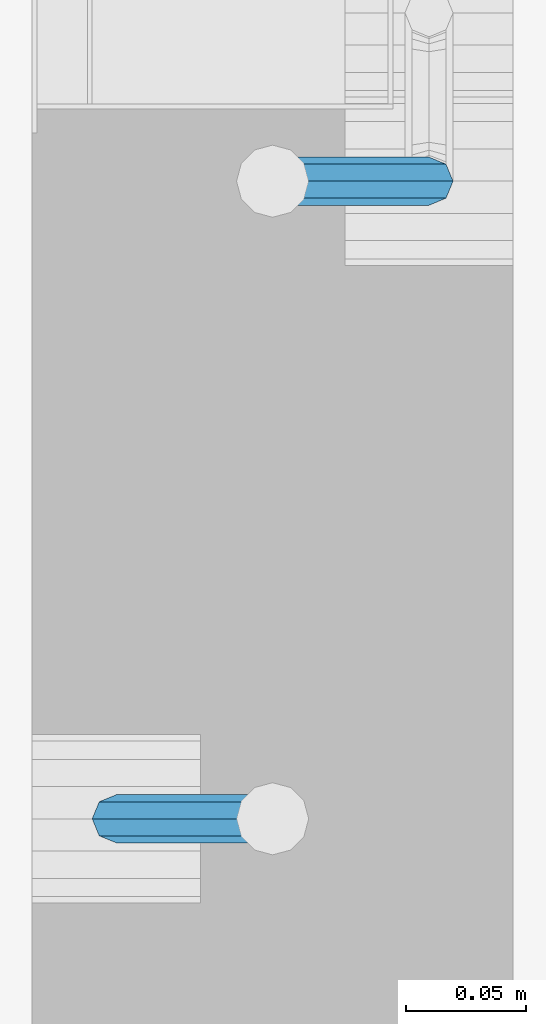
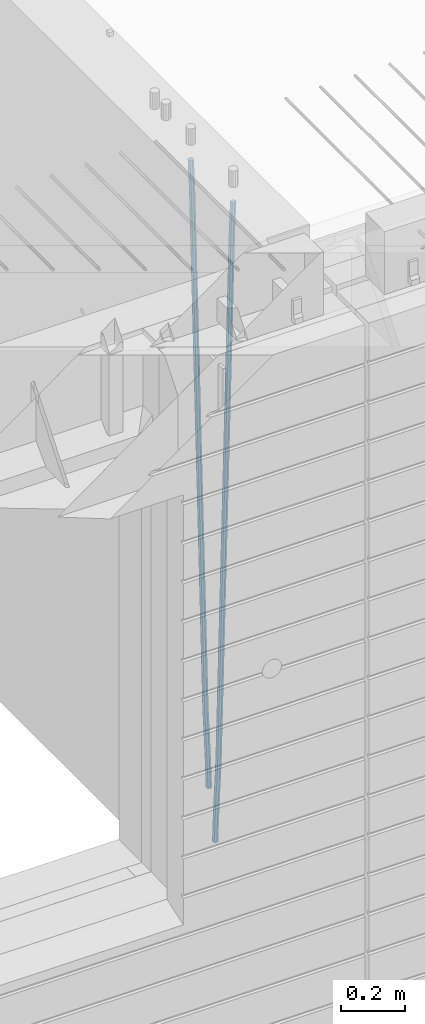
# One storey, part 101 of 350: 2 beams, 1 element without a shape of its own.
"""IFC2X3 building model written with IfcOpenShell, lengths in millimetres."""

from ifc_helpers import new_model, si_unit, frame, origin_with_axes, place, context, subcontext, project, spatial, faceted_brep, material, type_object, element, aggregate, save


model = new_model("IFC2X3")

# Units and contexts
model_context = context("Model", 3, precision=1e-05, world=origin_with_axes())
body_context = subcontext(model_context, "Body", "Model", "MODEL_VIEW")
ifc_project = project(units=[si_unit("LENGTHUNIT", "METRE", prefix="MILLI"), si_unit("AREAUNIT", "SQUARE_METRE"), si_unit("VOLUMEUNIT", "CUBIC_METRE"), si_unit("MASSUNIT", "GRAM", prefix="KILO"), si_unit("TIMEUNIT", "SECOND"), si_unit("PLANEANGLEUNIT", "RADIAN"), si_unit("SOLIDANGLEUNIT", "STERADIAN"), si_unit("THERMODYNAMICTEMPERATUREUNIT", "DEGREE_CELSIUS"), si_unit("LUMINOUSINTENSITYUNIT", "LUMEN")], contexts=[model_context])

# Site, building, storey
site_placement = place(None, origin_with_axes())
site = spatial("IfcSite", under=ifc_project, at=site_placement, CompositionType="ELEMENT")
building_placement = place(site_placement, origin_with_axes())
building = spatial("IfcBuilding", under=site, at=building_placement, CompositionType="ELEMENT")
storey_placement = place(building_placement, origin_with_axes())
storey = spatial("IfcBuildingStorey", under=building, at=storey_placement, Name="2", CompositionType="ELEMENT", Elevation=0.0)

# Assembly, beams
assembly_placement = place(storey_placement, origin_with_axes())
assembly = element("IfcElementAssembly", 1, at=assembly_placement, inside=storey, AssemblyPlace="NOTDEFINED", PredefinedType="REINFORCEMENT_UNIT")
ifc_material = material()
beam_type = type_object("IfcBeamType", Name="D20", PredefinedType="NOTDEFINED")
beam_1_placement = place(assembly_placement, frame((21744.9999977209, 8384.99999999607, 84990.0), z_axis=(0.999642804629538, 0.000205762999925497, -0.0267249099901003), x_axis=(0.0267249109941254, -4.30000210532798e-08, 0.999642825779465)))
beam_1 = element("IfcBeam", 2, at=beam_1_placement, type_object=beam_type, material=ifc_material, Name="JM20", ObjectType="D20", context=body_context, shape_type="Brep", body=[
    faceted_brep([(0.0, -10.0, 0.0), (-4.19531716033816e-08, -7.07106781186667, -7.07106781187031), (60.4266690400545, -7.0710677960451, -7.07106780570757), (60.4266690441291, -9.99999998418934, 6.15546014159918e-09), (0.0, 0.0, -10.0), (60.426669036824, 1.58106558956206e-08, -9.99999999384454), (4.196772351861e-08, 7.07106781186303, -7.07106781186667), (60.4266690363438, 7.07106782768096, -7.07106780570757), (0.0, 10.0, 0.0), (60.4266690388904, 10.0000000158179, 6.15182216279209e-09), (4.196772351861e-08, 7.07106781185939, 7.07106781185939), (60.4266690429649, 7.07106782768096, 7.07106781802577), (0.0, 0.0, 10.0), (60.4266690461809, 1.58179318532348e-08, 10.0000000061555), (-4.19531716033816e-08, -7.07106781187031, 7.07106781185939), (60.4266690466611, -7.07106779605238, 7.07106781802213), (61.0378400410118, -7.07106779588503, -7.07106780564936), (60.991799419251, -9.99999998403655, 6.21366780251265e-09), (61.0569027789461, 1.5985278878361e-08, -9.99999999378269), (61.0378209396877, 7.07106782784831, -7.07106780564936), (60.9917724058905, 10.0000000159635, 6.21366780251265e-09), (60.9457317841297, 7.07106782781193, 7.0710678180767), (60.9266690461809, 1.59488990902901e-08, 10.0000000062028), (60.9457508854539, -7.07106779591413, 7.0710678180767), (61.6489592143771, -7.07106614513759, -7.06310863441468), (61.5568818710308, -9.9999984576425, 0.00735959856683621), (61.6870830769039, 1.71821739058942e-06, -9.99179257185824), (61.6489210170112, 7.07106947854481, -7.06310888312146), (61.556827851804, 10.0000015422847, 0.00735924683976918), (61.4647505084577, 7.07106922979438, 7.07782747982128), (61.4266266459163, 1.36643211590126e-06, 10.0065114172685), (61.464788705809, -7.07106639389531, 7.07782772852806), (176.543135720174, -7.07075579406956, -5.56673531796696), (176.451058376813, -9.99968810657447, 1.50373291501455), (176.581259582701, 0.000312069292704109, -8.49541925541052), (176.543097522794, 7.07137982961285, -5.56673556667374), (176.451004357587, 10.00031189336, 1.50373256329476), (176.35892701424, 7.07137958085514, 8.57420079627263), (176.320803151699, 0.000311717507429421, 11.5028847337162), (176.358965211621, -7.07075604281999, 8.57420104497578), (177.098753836006, -7.07075429323595, -5.55949898843028), (176.98362511232, -9.99968666800123, 1.510669025065), (177.146421932586, 0.000313595905026887, -8.48805862247536), (177.098706077581, 7.07138133041735, -5.55949936166144), (176.983557571715, 10.0003133318824, 1.51066849724157), (176.868428848029, 7.07138095712435, 8.58083651073321), (176.820760751449, 0.000313067976094317, 11.5093961447819), (176.868476606425, -7.07075466652896, 8.58083688396073), (177.654312950661, -7.07075204110879, -5.54863964998367), (177.516135294456, -9.99968450931192, 1.52107783331303), (177.711524267797, 0.000315886711177882, -8.47701274570863), (177.654255632195, 7.07138358250813, -5.54864021007961), (177.516054233929, 10.0003154905207, 1.5210770412159), (177.377876577739, 7.0713830223176, 8.59079452451624), (177.320665260588, 0.000315094497636892, 11.5191676202448), (177.377933896176, -7.07075260129932, 8.59079508461218), (299.499456785634, -7.07025810522464, -3.16697112782276), (299.361279129444, -9.99919057342777, 3.90274635547394), (299.556668102785, 0.000809822595329024, -6.09534422354773), (299.499399467197, 7.07187751838501, -3.1669716879187), (299.361198068917, 10.0008094264049, 3.90274556338045), (299.223020412712, 7.07187695819448, 10.9724630466735), (299.165809095575, 0.000809030381788034, 13.9008361423985), (299.223077731163, -7.07025866542244, 10.9724636067695), (300.03174732349, -7.07025594743027, -3.15656661289177), (299.971788958996, -9.99918809853989, 3.91467979818117), (300.056572611924, 0.000811849109595641, -6.08557274808481), (300.031722507032, 7.07187967631762, -3.15656653768019), (299.971753863239, 10.0008119014747, 3.91467990454839), (299.91179549876, 7.07187975035777, 10.9859263156177), (299.886970210311, 0.000811953817901667, 13.9149324508144), (299.911820315203, -7.0702558733974, 10.9859262404061), (300.564137759997, -7.07025623699155, -3.15794273276697), (300.582413367199, -9.99918843065097, 3.91310145956595), (300.556570941641, 0.000811577163403854, -6.0868651410201), (300.564145451674, 7.07187938674906, -3.15794274158179), (300.582424244858, 10.0008115693345, 3.91310144710224), (300.600699852032, 7.07187937566778, 10.9841456394352), (300.608266670402, 0.000811561512819026, 13.9130680476919), (300.600692160384, -7.07025624805829, 10.98414564825), (2294.16589219622, -7.0713405251372, -8.31099358700158), (2294.1841678034, -10.0002727187966, -1.23994939466866), (2294.15832537785, -0.000272710982244462, -11.2399159952547), (2294.16589988787, 7.07079509858886, -8.31099359582004), (2294.18417868105, 9.99972728118883, -1.23994940713601), (2294.20245428824, 7.07079508752213, 5.83109478519327), (2294.2100211066, -0.00027272663282929, 8.76001719345368), (2294.20244659658, -7.07134053620393, 5.83109479401173), (2294.7782683276, -7.07134085819416, -8.31257645345977), (2294.72126025338, -10.000273010919, -1.24133766827799), (2294.84007459224, -0.000273081772320438, -11.2416781768807), (2294.87047377572, 7.07079471537872, -8.31281477453012), (2294.85165844864, 9.9997269181622, -1.24167470516841), (2294.7946503744, 7.07079476544459, 5.82956408001337), (2294.73284410976, -0.000273010977252852, 8.75866580342336), (2294.7024449263, -7.07134080815013, 5.82980240107645), (2295.39054023061, -7.0793250091956, -8.30442771922026), (2295.25826128852, -10.0072756143927, -1.23419071494573), (2295.52170777075, -0.00916171800054144, -11.2326063125765), (2295.57492774284, 7.06160849139269, -8.30343918807193), (2295.51902460904, 9.99102432676591, -1.23279272078435), (2295.38674566693, 7.06307372157607, 5.83744428349019), (2295.25557812679, -0.0070895696117077, 8.76562287684646), (2295.20235815471, -7.07785977901949, 5.83645575234186), (2317.1947101649, -7.36365585014573, -8.01423575520312), (2317.06243122277, -10.2916064553428, -0.94399875092131), (2317.32587770502, -0.293492558957951, -10.9424143485521), (2317.37909767711, 6.77727765044983, -8.01324722405116), (2317.32319454331, 9.70669348581578, -0.942600756767206), (2317.1909156012, 6.77874288063322, 6.12763624751096), (2317.05974806109, -0.291420410569117, 9.0558148408636), (2317.00652808898, -7.36219061996962, 6.12664771636264), (2317.83015404257, -7.37194216843636, -8.00577862486898), (2317.72252095213, -10.300214160583, -0.935213608652703), (2317.90419832576, -0.301033978277701, -10.9347174723516), (2317.90127966482, 6.77046829039318, -8.00629749759901), (2317.82310777172, 9.70017451494641, -0.935947405505431), (2317.71547468127, 6.77190252279979, 6.13461761071085), (2317.64143039809, -0.29900566735887, 9.06355645819713), (2317.64434905903, -7.37050793602975, 6.13513648344451), (2318.46565174212, -7.3700661537805, -7.99751648408346), (2318.38266643914, -10.2982456018653, -0.926623872735945), (2318.48256818345, -0.299336209594912, -10.9272153854981), (2318.42350634121, 6.77200652527245, -7.99954269419686), (2318.32306384158, 9.70166538090416, -0.929489366557391), (2318.2400785386, 6.77348593281204, 6.14140324480104), (2318.22316209726, -0.297244011366274, 9.07110214621207), (2318.2822239395, -7.36858674623363, 6.1434294549108), (2418.48643733139, -7.07180401323421, -6.70013846199799), (2418.4034520284, -9.99998346132634, 0.370754149349523), (2418.5033537727, -0.00107406904135132, -9.62983736341266), (2418.44429193046, 7.07026866581873, -6.70216467211139), (2418.34384943081, 9.99992752145772, 0.367888655531715), (2418.26086412782, 7.0717480733656, 7.43878126688651), (2418.24394768651, 0.00101812917273492, 10.3684801682975), (2418.30300952874, -7.07032460568735, 7.44080747699627)], [[[0, 1, 2, 3]], [[1, 4, 5, 2]], [[4, 6, 7, 5]], [[6, 8, 9, 7]], [[8, 10, 11, 9]], [[10, 12, 13, 11]], [[12, 14, 15, 13]], [[14, 0, 3, 15]], [[14, 12, 10, 8, 6, 4, 1, 0]], [[3, 2, 16, 17]], [[2, 5, 18, 16]], [[5, 7, 19, 18]], [[7, 9, 20, 19]], [[9, 11, 21, 20]], [[11, 13, 22, 21]], [[13, 15, 23, 22]], [[15, 3, 17, 23]], [[17, 16, 24, 25]], [[16, 18, 26, 24]], [[18, 19, 27, 26]], [[19, 20, 28, 27]], [[20, 21, 29, 28]], [[21, 22, 30, 29]], [[22, 23, 31, 30]], [[23, 17, 25, 31]], [[25, 24, 32, 33]], [[24, 26, 34, 32]], [[26, 27, 35, 34]], [[27, 28, 36, 35]], [[28, 29, 37, 36]], [[29, 30, 38, 37]], [[30, 31, 39, 38]], [[31, 25, 33, 39]], [[33, 32, 40, 41]], [[32, 34, 42, 40]], [[34, 35, 43, 42]], [[35, 36, 44, 43]], [[36, 37, 45, 44]], [[37, 38, 46, 45]], [[38, 39, 47, 46]], [[39, 33, 41, 47]], [[41, 40, 48, 49]], [[40, 42, 50, 48]], [[42, 43, 51, 50]], [[43, 44, 52, 51]], [[44, 45, 53, 52]], [[45, 46, 54, 53]], [[46, 47, 55, 54]], [[47, 41, 49, 55]], [[49, 48, 56, 57]], [[48, 50, 58, 56]], [[50, 51, 59, 58]], [[51, 52, 60, 59]], [[52, 53, 61, 60]], [[53, 54, 62, 61]], [[54, 55, 63, 62]], [[55, 49, 57, 63]], [[57, 56, 64, 65]], [[56, 58, 66, 64]], [[58, 59, 67, 66]], [[59, 60, 68, 67]], [[60, 61, 69, 68]], [[61, 62, 70, 69]], [[62, 63, 71, 70]], [[63, 57, 65, 71]], [[65, 64, 72, 73]], [[64, 66, 74, 72]], [[66, 67, 75, 74]], [[67, 68, 76, 75]], [[68, 69, 77, 76]], [[69, 70, 78, 77]], [[70, 71, 79, 78]], [[71, 65, 73, 79]], [[73, 72, 80, 81]], [[72, 74, 82, 80]], [[74, 75, 83, 82]], [[75, 76, 84, 83]], [[76, 77, 85, 84]], [[77, 78, 86, 85]], [[78, 79, 87, 86]], [[79, 73, 81, 87]], [[81, 80, 88, 89]], [[80, 82, 90, 88]], [[82, 83, 91, 90]], [[83, 84, 92, 91]], [[84, 85, 93, 92]], [[85, 86, 94, 93]], [[86, 87, 95, 94]], [[87, 81, 89, 95]], [[89, 88, 96, 97]], [[88, 90, 98, 96]], [[90, 91, 99, 98]], [[91, 92, 100, 99]], [[92, 93, 101, 100]], [[93, 94, 102, 101]], [[94, 95, 103, 102]], [[95, 89, 97, 103]], [[97, 96, 104, 105]], [[96, 98, 106, 104]], [[98, 99, 107, 106]], [[99, 100, 108, 107]], [[100, 101, 109, 108]], [[101, 102, 110, 109]], [[102, 103, 111, 110]], [[103, 97, 105, 111]], [[105, 104, 112, 113]], [[104, 106, 114, 112]], [[106, 107, 115, 114]], [[107, 108, 116, 115]], [[108, 109, 117, 116]], [[109, 110, 118, 117]], [[110, 111, 119, 118]], [[111, 105, 113, 119]], [[113, 112, 120, 121]], [[112, 114, 122, 120]], [[114, 115, 123, 122]], [[115, 116, 124, 123]], [[116, 117, 125, 124]], [[117, 118, 126, 125]], [[118, 119, 127, 126]], [[119, 113, 121, 127]], [[121, 120, 128, 129]], [[120, 122, 130, 128]], [[122, 123, 131, 130]], [[123, 124, 132, 131]], [[124, 125, 133, 132]], [[125, 126, 134, 133]], [[126, 127, 135, 134]], [[127, 121, 129, 135]], [[130, 131, 132, 133, 134, 135, 129, 128]]]),
])
beam_2_placement = place(assembly_placement, frame((21875.0000022791, 8650.00000000393, 84990.0), z_axis=(-0.999642804636942, -0.000205726999925762, -0.0267249099902983), x_axis=(-0.0267249099948371, 4.30000201934385e-08, 0.999642825806181)))
beam_2 = element("IfcBeam", 3, at=beam_2_placement, type_object=beam_type, material=ifc_material, Name="JM20", ObjectType="D20", context=body_context, shape_type="Brep", body=[
    faceted_brep([(0.0, -10.0, 0.0), (-4.19531716033816e-08, -7.07106781186667, -7.07106781187031), (60.4266690400545, -7.0710677960451, -7.07106780570757), (60.4266690441291, -9.99999998418934, 6.15546014159918e-09), (0.0, 0.0, -10.0), (60.426669036824, 1.58106558956206e-08, -9.99999999384454), (4.196772351861e-08, 7.07106781186303, -7.07106781186667), (60.4266690363438, 7.07106782768096, -7.07106780570757), (0.0, 10.0, 0.0), (60.4266690388904, 10.0000000158179, 6.15182216279209e-09), (4.196772351861e-08, 7.07106781185939, 7.07106781185939), (60.4266690429649, 7.07106782768096, 7.07106781802577), (0.0, 0.0, 10.0), (60.4266690461809, 1.58179318532348e-08, 10.0000000061555), (-4.19531716033816e-08, -7.07106781187031, 7.07106781185939), (60.4266690466611, -7.07106779605238, 7.07106781802213), (61.0378400410118, -7.07106779588503, -7.07106780564936), (60.991799419251, -9.99999998403655, 6.21366780251265e-09), (61.0569027789461, 1.5985278878361e-08, -9.99999999378269), (61.0378209396877, 7.07106782784831, -7.07106780564936), (60.9917724058905, 10.0000000159635, 6.21366780251265e-09), (60.9457317841297, 7.07106782781193, 7.0710678180767), (60.9266690461809, 1.59488990902901e-08, 10.0000000062028), (60.9457508854539, -7.07106779591413, 7.0710678180767), (61.6489592143771, -7.07106614513759, -7.06310863441468), (61.5568818710308, -9.9999984576425, 0.00735959856683621), (61.6870830769039, 1.71821739058942e-06, -9.99179257185824), (61.6489210170112, 7.07106947854481, -7.06310888312146), (61.556827851804, 10.0000015422847, 0.00735924683976918), (61.4647505084577, 7.07106922979438, 7.07782747982128), (61.4266266459163, 1.36643211590126e-06, 10.0065114172685), (61.464788705809, -7.07106639389531, 7.07782772852806), (176.543135720174, -7.07075579406956, -5.56673531796696), (176.451058376813, -9.99968810657447, 1.50373291501455), (176.581259582701, 0.000312069292704109, -8.49541925541052), (176.543097522794, 7.07137982961285, -5.56673556667374), (176.451004357587, 10.00031189336, 1.50373256329476), (176.35892701424, 7.07137958085514, 8.57420079627263), (176.320803151699, 0.000311717507429421, 11.5028847337162), (176.358965211621, -7.07075604281999, 8.57420104497578), (177.098753836006, -7.07075429323595, -5.55949898843028), (176.98362511232, -9.99968666800123, 1.510669025065), (177.146421932586, 0.000313595905026887, -8.48805862247536), (177.098706077581, 7.07138133041735, -5.55949936166144), (176.983557571715, 10.0003133318824, 1.51066849724157), (176.868428848029, 7.07138095712435, 8.58083651073321), (176.820760751449, 0.000313067976094317, 11.5093961447819), (176.868476606425, -7.07075466652896, 8.58083688396073), (177.654312950661, -7.07075204110879, -5.54863964998367), (177.516135294456, -9.99968450931192, 1.52107783331303), (177.711524267797, 0.000315886711177882, -8.47701274570863), (177.654255632195, 7.07138358250813, -5.54864021007961), (177.516054233929, 10.0003154905207, 1.5210770412159), (177.377876577739, 7.0713830223176, 8.59079452451624), (177.320665260588, 0.000315094497636892, 11.5191676202448), (177.377933896176, -7.07075260129932, 8.59079508461218), (299.499456785634, -7.07025810522464, -3.16697112782276), (299.361279129444, -9.99919057342777, 3.90274635547394), (299.556668102785, 0.000809822595329024, -6.09534422354773), (299.499399467197, 7.07187751838501, -3.1669716879187), (299.361198068917, 10.0008094264049, 3.90274556338045), (299.223020412712, 7.07187695819448, 10.9724630466735), (299.165809095575, 0.000809030381788034, 13.9008361423985), (299.223077731163, -7.07025866542244, 10.9724636067695), (300.03174732349, -7.07025594743027, -3.15656661289177), (299.971788958996, -9.99918809853989, 3.91467979818117), (300.056572611924, 0.000811849109595641, -6.08557274808481), (300.031722507032, 7.07187967631762, -3.15656653768019), (299.971753863239, 10.0008119014747, 3.91467990454839), (299.91179549876, 7.07187975035777, 10.9859263156177), (299.886970210311, 0.000811953817901667, 13.9149324508144), (299.911820315203, -7.0702558733974, 10.9859262404061), (300.564137759997, -7.07025623699155, -3.15794273276697), (300.582413367199, -9.99918843065097, 3.91310145956595), (300.556570941641, 0.000811577163403854, -6.0868651410201), (300.564145451674, 7.07187938674906, -3.15794274158179), (300.582424244858, 10.0008115693345, 3.91310144710224), (300.600699852032, 7.07187937566778, 10.9841456394352), (300.608266670402, 0.000811561512819026, 13.9130680476919), (300.600692160384, -7.07025624805829, 10.98414564825), (2294.16589219622, -7.0713405251372, -8.31099358700158), (2294.1841678034, -10.0002727187966, -1.23994939466866), (2294.15832537785, -0.000272710982244462, -11.2399159952547), (2294.16589988787, 7.07079509858886, -8.31099359582004), (2294.18417868105, 9.99972728118883, -1.23994940713601), (2294.20245428824, 7.07079508752213, 5.83109478519327), (2294.2100211066, -0.00027272663282929, 8.76001719345368), (2294.20244659658, -7.07134053620393, 5.83109479401173), (2294.7782683276, -7.07134085819416, -8.31257645345977), (2294.72126025338, -10.000273010919, -1.24133766827799), (2294.84007459224, -0.000273081772320438, -11.2416781768807), (2294.87047377572, 7.07079471537872, -8.31281477453012), (2294.85165844864, 9.9997269181622, -1.24167470516841), (2294.7946503744, 7.07079476544459, 5.82956408001337), (2294.73284410976, -0.000273010977252852, 8.75866580342336), (2294.7024449263, -7.07134080815013, 5.82980240107645), (2295.39054023061, -7.0793250091956, -8.30442771922026), (2295.25826128852, -10.0072756143927, -1.23419071494573), (2295.52170777075, -0.00916171800054144, -11.2326063125765), (2295.57492774284, 7.06160849139269, -8.30343918807193), (2295.51902460904, 9.99102432676591, -1.23279272078435), (2295.38674566693, 7.06307372157607, 5.83744428349019), (2295.25557812679, -0.0070895696117077, 8.76562287684646), (2295.20235815471, -7.07785977901949, 5.83645575234186), (2317.1947101649, -7.36365585014573, -8.01423575520312), (2317.06243122277, -10.2916064553428, -0.94399875092131), (2317.32587770502, -0.293492558957951, -10.9424143485521), (2317.37909767711, 6.77727765044983, -8.01324722405116), (2317.32319454331, 9.70669348581578, -0.942600756767206), (2317.1909156012, 6.77874288063322, 6.12763624751096), (2317.05974806109, -0.291420410569117, 9.0558148408636), (2317.00652808898, -7.36219061996962, 6.12664771636264), (2317.83015404257, -7.37194216843636, -8.00577862486898), (2317.72252095213, -10.300214160583, -0.935213608652703), (2317.90419832576, -0.301033978277701, -10.9347174723516), (2317.90127966482, 6.77046829039318, -8.00629749759901), (2317.82310777172, 9.70017451494641, -0.935947405505431), (2317.71547468127, 6.77190252279979, 6.13461761071085), (2317.64143039809, -0.29900566735887, 9.06355645819713), (2317.64434905903, -7.37050793602975, 6.13513648344451), (2318.46565174212, -7.3700661537805, -7.99751648408346), (2318.38266643914, -10.2982456018653, -0.926623872735945), (2318.48256818345, -0.299336209594912, -10.9272153854981), (2318.42350634121, 6.77200652527245, -7.99954269419686), (2318.32306384158, 9.70166538090416, -0.929489366557391), (2318.2400785386, 6.77348593281204, 6.14140324480104), (2318.22316209726, -0.297244011366274, 9.07110214621207), (2318.2822239395, -7.36858674623363, 6.1434294549108), (2418.48643733139, -7.07180401323421, -6.70013846199799), (2418.4034520284, -9.99998346132634, 0.370754149349523), (2418.5033537727, -0.00107406904135132, -9.62983736341266), (2418.44429193046, 7.07026866581873, -6.70216467211139), (2418.34384943081, 9.99992752145772, 0.367888655531715), (2418.26086412782, 7.0717480733656, 7.43878126688651), (2418.24394768651, 0.00101812917273492, 10.3684801682975), (2418.30300952874, -7.07032460568735, 7.44080747699627)], [[[0, 1, 2, 3]], [[1, 4, 5, 2]], [[4, 6, 7, 5]], [[6, 8, 9, 7]], [[8, 10, 11, 9]], [[10, 12, 13, 11]], [[12, 14, 15, 13]], [[14, 0, 3, 15]], [[14, 12, 10, 8, 6, 4, 1, 0]], [[3, 2, 16, 17]], [[2, 5, 18, 16]], [[5, 7, 19, 18]], [[7, 9, 20, 19]], [[9, 11, 21, 20]], [[11, 13, 22, 21]], [[13, 15, 23, 22]], [[15, 3, 17, 23]], [[17, 16, 24, 25]], [[16, 18, 26, 24]], [[18, 19, 27, 26]], [[19, 20, 28, 27]], [[20, 21, 29, 28]], [[21, 22, 30, 29]], [[22, 23, 31, 30]], [[23, 17, 25, 31]], [[25, 24, 32, 33]], [[24, 26, 34, 32]], [[26, 27, 35, 34]], [[27, 28, 36, 35]], [[28, 29, 37, 36]], [[29, 30, 38, 37]], [[30, 31, 39, 38]], [[31, 25, 33, 39]], [[33, 32, 40, 41]], [[32, 34, 42, 40]], [[34, 35, 43, 42]], [[35, 36, 44, 43]], [[36, 37, 45, 44]], [[37, 38, 46, 45]], [[38, 39, 47, 46]], [[39, 33, 41, 47]], [[41, 40, 48, 49]], [[40, 42, 50, 48]], [[42, 43, 51, 50]], [[43, 44, 52, 51]], [[44, 45, 53, 52]], [[45, 46, 54, 53]], [[46, 47, 55, 54]], [[47, 41, 49, 55]], [[49, 48, 56, 57]], [[48, 50, 58, 56]], [[50, 51, 59, 58]], [[51, 52, 60, 59]], [[52, 53, 61, 60]], [[53, 54, 62, 61]], [[54, 55, 63, 62]], [[55, 49, 57, 63]], [[57, 56, 64, 65]], [[56, 58, 66, 64]], [[58, 59, 67, 66]], [[59, 60, 68, 67]], [[60, 61, 69, 68]], [[61, 62, 70, 69]], [[62, 63, 71, 70]], [[63, 57, 65, 71]], [[65, 64, 72, 73]], [[64, 66, 74, 72]], [[66, 67, 75, 74]], [[67, 68, 76, 75]], [[68, 69, 77, 76]], [[69, 70, 78, 77]], [[70, 71, 79, 78]], [[71, 65, 73, 79]], [[73, 72, 80, 81]], [[72, 74, 82, 80]], [[74, 75, 83, 82]], [[75, 76, 84, 83]], [[76, 77, 85, 84]], [[77, 78, 86, 85]], [[78, 79, 87, 86]], [[79, 73, 81, 87]], [[81, 80, 88, 89]], [[80, 82, 90, 88]], [[82, 83, 91, 90]], [[83, 84, 92, 91]], [[84, 85, 93, 92]], [[85, 86, 94, 93]], [[86, 87, 95, 94]], [[87, 81, 89, 95]], [[89, 88, 96, 97]], [[88, 90, 98, 96]], [[90, 91, 99, 98]], [[91, 92, 100, 99]], [[92, 93, 101, 100]], [[93, 94, 102, 101]], [[94, 95, 103, 102]], [[95, 89, 97, 103]], [[97, 96, 104, 105]], [[96, 98, 106, 104]], [[98, 99, 107, 106]], [[99, 100, 108, 107]], [[100, 101, 109, 108]], [[101, 102, 110, 109]], [[102, 103, 111, 110]], [[103, 97, 105, 111]], [[105, 104, 112, 113]], [[104, 106, 114, 112]], [[106, 107, 115, 114]], [[107, 108, 116, 115]], [[108, 109, 117, 116]], [[109, 110, 118, 117]], [[110, 111, 119, 118]], [[111, 105, 113, 119]], [[113, 112, 120, 121]], [[112, 114, 122, 120]], [[114, 115, 123, 122]], [[115, 116, 124, 123]], [[116, 117, 125, 124]], [[117, 118, 126, 125]], [[118, 119, 127, 126]], [[119, 113, 121, 127]], [[121, 120, 128, 129]], [[120, 122, 130, 128]], [[122, 123, 131, 130]], [[123, 124, 132, 131]], [[124, 125, 133, 132]], [[125, 126, 134, 133]], [[126, 127, 135, 134]], [[127, 121, 129, 135]], [[130, 131, 132, 133, 134, 135, 129, 128]]]),
])
aggregate(assembly, [beam_1, beam_2])

save(model, "model.ifc")
